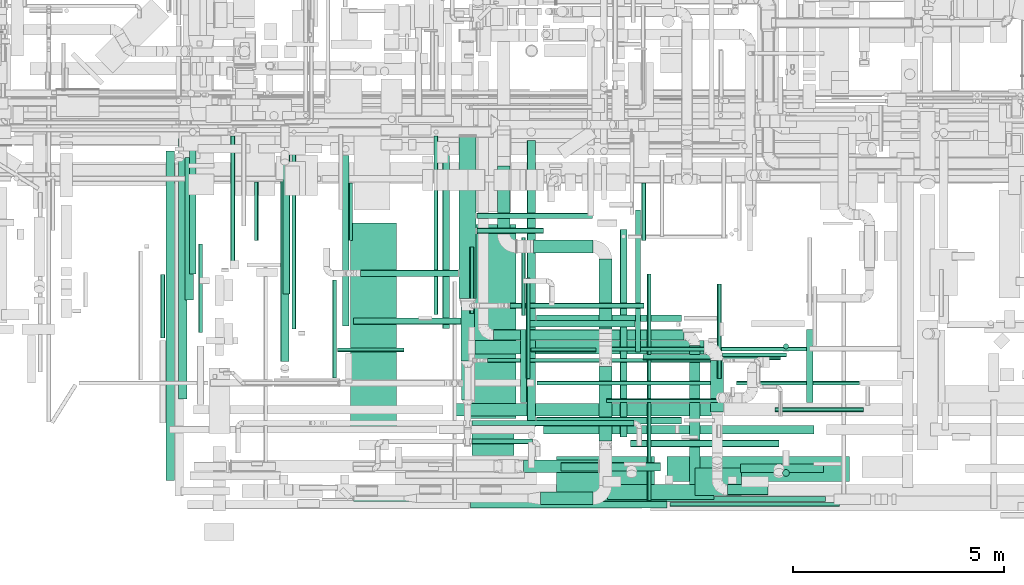
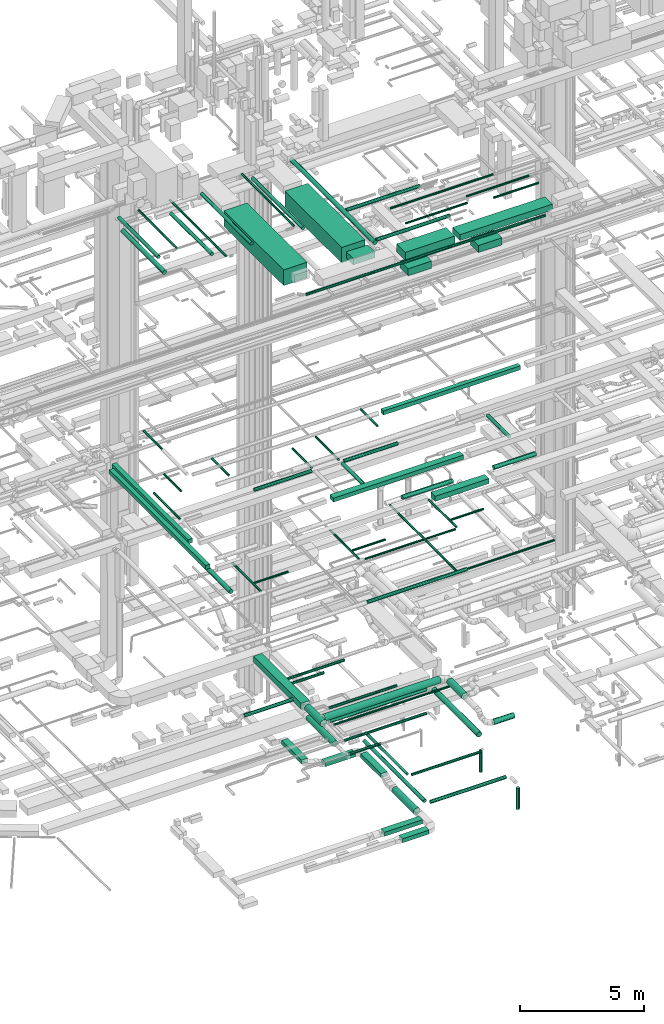
# One storey, part 30 of 337: 79 flow segments.
"""IFC2X3 building model written with IfcOpenShell, lengths in millimetres."""

from ifc_helpers import new_model, entity, si_unit, converted_unit, derived_unit, direction, frame, origin, origin_2d_with_axis, place, context, subcontext, project, spatial, rectangle, circle, extrude, type_object, element, save


model = new_model("IFC2X3")

# Units and contexts
model_context = context("Model", 3, precision=0.01, world=origin(), true_north=direction((6.12303176911189e-17, 1.0)))
body_context = subcontext(model_context, "Body", "Model", "MODEL_VIEW")
ifc_project = project(units=[si_unit("LENGTHUNIT", "METRE", prefix="MILLI"), si_unit("AREAUNIT", "SQUARE_METRE"), si_unit("VOLUMEUNIT", "CUBIC_METRE"), converted_unit("PLANEANGLEUNIT", "DEGREE", entity("IfcRatioMeasure", 0.0174532925199433), si_unit("PLANEANGLEUNIT", "RADIAN"), dimensions=[0, 0, 0, 0, 0, 0, 0]), si_unit("MASSUNIT", "GRAM", prefix="KILO"), derived_unit("MASSDENSITYUNIT", [(si_unit("MASSUNIT", "GRAM", prefix="KILO"), 1), (si_unit("LENGTHUNIT", "METRE"), -3)]), derived_unit("MOMENTOFINERTIAUNIT", [(si_unit("LENGTHUNIT", "METRE"), 4)]), si_unit("TIMEUNIT", "SECOND"), si_unit("FREQUENCYUNIT", "HERTZ"), si_unit("THERMODYNAMICTEMPERATUREUNIT", "DEGREE_CELSIUS"), derived_unit("THERMALTRANSMITTANCEUNIT", [(si_unit("MASSUNIT", "GRAM", prefix="KILO"), 1), (si_unit("THERMODYNAMICTEMPERATUREUNIT", "KELVIN"), -1), (si_unit("TIMEUNIT", "SECOND"), -3)]), derived_unit("VOLUMETRICFLOWRATEUNIT", [(si_unit("LENGTHUNIT", "METRE"), 3), (si_unit("TIMEUNIT", "SECOND"), -1)]), derived_unit("MASSFLOWRATEUNIT", [(si_unit("MASSUNIT", "GRAM", prefix="KILO"), 1), (si_unit("TIMEUNIT", "SECOND"), -1)]), derived_unit("ROTATIONALFREQUENCYUNIT", [(si_unit("TIMEUNIT", "SECOND"), -1)]), si_unit("ELECTRICCURRENTUNIT", "AMPERE"), si_unit("ELECTRICVOLTAGEUNIT", "VOLT"), si_unit("POWERUNIT", "WATT"), si_unit("FORCEUNIT", "NEWTON", prefix="KILO"), si_unit("ILLUMINANCEUNIT", "LUX"), si_unit("LUMINOUSFLUXUNIT", "LUMEN"), si_unit("LUMINOUSINTENSITYUNIT", "CANDELA"), derived_unit("USERDEFINED", [(si_unit("MASSUNIT", "GRAM", prefix="KILO"), -1), (si_unit("LENGTHUNIT", "METRE"), -2), (si_unit("TIMEUNIT", "SECOND"), 3), (si_unit("LUMINOUSFLUXUNIT", "LUMEN"), 1)]), derived_unit("LINEARVELOCITYUNIT", [(si_unit("LENGTHUNIT", "METRE"), 1), (si_unit("TIMEUNIT", "SECOND"), -1)]), si_unit("PRESSUREUNIT", "PASCAL"), derived_unit("USERDEFINED", [(si_unit("LENGTHUNIT", "METRE"), -2), (si_unit("MASSUNIT", "GRAM", prefix="KILO"), 1), (si_unit("TIMEUNIT", "SECOND"), -2)]), derived_unit("LINEARFORCEUNIT", [(si_unit("MASSUNIT", "GRAM", prefix="KILO"), 1), (si_unit("LENGTHUNIT", "METRE"), 1), (si_unit("TIMEUNIT", "SECOND"), -2), (si_unit("LENGTHUNIT", "METRE"), -1)]), derived_unit("PLANARFORCEUNIT", [(si_unit("MASSUNIT", "GRAM", prefix="KILO"), 1), (si_unit("LENGTHUNIT", "METRE"), 1), (si_unit("TIMEUNIT", "SECOND"), -2), (si_unit("LENGTHUNIT", "METRE"), -2)])], contexts=[model_context])

# Site, building, storey
site_placement = place(None, origin())
site = spatial("IfcSite", under=ifc_project, at=site_placement, CompositionType="ELEMENT")
building_placement = place(site_placement, origin())
building = spatial("IfcBuilding", under=site, at=building_placement, CompositionType="ELEMENT")
storey_placement = place(building_placement, origin())
storey = spatial("IfcBuildingStorey", under=building, at=storey_placement, CompositionType="ELEMENT", Elevation=0.0)

# Flow segments
duct_segment_type_1 = type_object("IfcDuctSegmentType", PredefinedType="NOTDEFINED")
flow_segment_1_placement = place(storey_placement, frame((30327.78, 6910.62, -650.0)))
element("IfcFlowSegment", 1, at=flow_segment_1_placement, inside=storey, type_object=duct_segment_type_1, context=body_context, shape_type="SweptSolid", body=[
    extrude(rectangle(XDim=1613.81498356853, YDim=300.000000000001, at=origin_2d_with_axis()), frame((150.0, 806.91, 0.0), z_axis=(0.0, 0.0, 1.0), x_axis=(0.0, 1.0, 0.0)), (0.0, 0.0, 1.0), 200.0),
])
flow_segment_2_placement = place(storey_placement, frame((32739.74, 4657.73, -800.0)))
element("IfcFlowSegment", 2, at=flow_segment_2_placement, inside=storey, type_object=duct_segment_type_1, context=body_context, shape_type="SweptSolid", body=[
    extrude(rectangle(XDim=1652.88388777232, YDim=300.000000000001, at=origin_2d_with_axis()), frame((150.0, 826.44, 0.0), z_axis=(0.0, 0.0, 1.0), x_axis=(0.0, -1.0, 0.0)), (0.0, 0.0, 1.0), 200.0),
])
flow_segment_3_placement = place(storey_placement, frame((31351.06, 498.22, -1000.0)))
element("IfcFlowSegment", 3, at=flow_segment_3_placement, inside=storey, type_object=duct_segment_type_1, context=body_context, shape_type="SweptSolid", body=[
    extrude(rectangle(XDim=1238.6873062339, YDim=300.0, at=origin_2d_with_axis()), frame((619.34, 150.0, 0.0), z_axis=(0.0, 0.0, 1.0), x_axis=(-1.0, 0.0, 0.0)), (0.0, 0.0, 1.0), 200.0),
])
flow_segment_4_placement = place(storey_placement, frame((30943.84, 1257.6, -1000.0)))
element("IfcFlowSegment", 4, at=flow_segment_4_placement, inside=storey, type_object=duct_segment_type_1, context=body_context, shape_type="SweptSolid", body=[
    extrude(rectangle(XDim=1775.90363974999, YDim=300.0, at=origin_2d_with_axis()), frame((887.95, 150.0, 0.0), z_axis=(0.0, 0.0, 1.0), x_axis=(-1.0, 0.0, 0.0)), (0.0, 0.0, 1.0), 200.0),
])
flow_segment_5_placement = place(storey_placement, frame((29425.76, 5379.25, 3300.0)))
element("IfcFlowSegment", 5, at=flow_segment_5_placement, inside=storey, type_object=duct_segment_type_1, context=body_context, shape_type="SweptSolid", body=[
    extrude(rectangle(XDim=3849.82756057298, YDim=400.0, at=origin_2d_with_axis()), frame((200.0, 1924.91, 0.0), z_axis=(0.0, 0.0, 1.0), x_axis=(0.0, 1.0, 0.0)), (0.0, 0.0, 1.0), 300.0),
])
flow_segment_6_placement = place(storey_placement, frame((31425.22, 2176.32, 19075.0)))
element("IfcFlowSegment", 6, at=flow_segment_6_placement, inside=storey, type_object=duct_segment_type_1, context=body_context, shape_type="SweptSolid", body=[
    extrude(rectangle(XDim=6399.99999999994, YDim=200.0, at=origin_2d_with_axis()), frame((3200.0, 100.0, 0.0), z_axis=(0.0, 0.0, 1.0), x_axis=(-1.0, 0.0, 0.0)), (0.0, 0.0, 1.0), 199.999999999998),
])
flow_segment_7_placement = place(storey_placement, frame((29338.8, 2599.02, 15250.0)))
element("IfcFlowSegment", 7, at=flow_segment_7_placement, inside=storey, type_object=duct_segment_type_1, context=body_context, shape_type="SweptSolid", body=[
    extrude(rectangle(XDim=6062.99999999993, YDim=300.0, at=origin_2d_with_axis()), frame((3031.5, 150.0, 0.0)), (0.0, 0.0, 1.0), 199.999999999998),
])
flow_segment_8_placement = place(storey_placement, frame((32940.93, 620.66, 15225.0)))
element("IfcFlowSegment", 8, at=flow_segment_8_placement, inside=storey, type_object=duct_segment_type_1, context=body_context, shape_type="SweptSolid", body=[
    extrude(rectangle(XDim=2514.00000000004, YDim=350.0, at=origin_2d_with_axis()), frame((1257.0, 175.0, 0.0)), (0.0, 0.0, 1.0), 249.999999999999),
])
flow_segment_9_placement = place(storey_placement, frame((22482.56, 1070.66, 15250.0)))
element("IfcFlowSegment", 9, at=flow_segment_9_placement, inside=storey, type_object=duct_segment_type_1, context=body_context, shape_type="SweptSolid", body=[
    extrude(rectangle(XDim=7807.60125080103, YDim=199.999999999998, at=origin_2d_with_axis()), frame((100.0, 3903.8, 0.0), z_axis=(0.0, 0.0, 1.0), x_axis=(0.0, -1.0, 0.0)), (0.0, 0.0, 1.0), 200.000000000002),
])
flow_segment_10_placement = place(storey_placement, frame((22777.55, 2999.02, 15250.0)))
element("IfcFlowSegment", 10, at=flow_segment_10_placement, inside=storey, type_object=duct_segment_type_1, context=body_context, shape_type="SweptSolid", body=[
    extrude(rectangle(XDim=6170.97709351263, YDim=200.000000000002, at=origin_2d_with_axis()), frame((100.0, 3085.49, 0.0), z_axis=(0.0, 0.0, 1.0), x_axis=(0.0, 1.0, 0.0)), (0.0, 0.0, 1.0), 200.000000000002),
])
flow_segment_11_placement = place(storey_placement, frame((26855.62, 2334.06, 26975.0)))
element("IfcFlowSegment", 11, at=flow_segment_11_placement, inside=storey, type_object=duct_segment_type_1, context=body_context, shape_type="SweptSolid", body=[
    extrude(rectangle(XDim=4840.00000000023, YDim=1090.0, at=origin_2d_with_axis()), frame((545.0, 2420.0, 0.0), z_axis=(0.0, 0.0, 1.0), x_axis=(0.0, -1.0, 0.0)), (0.0, 0.0, 1.0), 769.999999999998),
])
flow_segment_12_placement = place(storey_placement, frame((34353.0, 1044.06, 27350.0)))
element("IfcFlowSegment", 12, at=flow_segment_12_placement, inside=storey, type_object=duct_segment_type_1, context=body_context, shape_type="SweptSolid", body=[
    extrude(rectangle(XDim=4317.00000000009, YDim=600.0, at=origin_2d_with_axis()), frame((2158.5, 300.0, 0.0), z_axis=(0.0, 0.0, 1.0), x_axis=(-1.0, 0.0, 0.0)), (0.0, 0.0, 1.0), 300.000000000001),
])
flow_segment_13_placement = place(storey_placement, frame((29679.65, 2532.81, 26980.0)))
element("IfcFlowSegment", 13, at=flow_segment_13_placement, inside=storey, type_object=duct_segment_type_1, context=body_context, shape_type="SweptSolid", body=[
    extrude(rectangle(XDim=4600.00000000022, YDim=1090.0, at=origin_2d_with_axis()), frame((545.0, 2300.0, 0.0), z_axis=(0.0, 0.0, 1.0), x_axis=(0.0, -1.0, 0.0)), (0.0, 0.0, 1.0), 769.999999999998),
])
flow_segment_14_placement = place(storey_placement, frame((29724.65, 1664.06, 27400.0)))
element("IfcFlowSegment", 14, at=flow_segment_14_placement, inside=storey, type_object=duct_segment_type_1, context=body_context, shape_type="SweptSolid", body=[
    extrude(rectangle(XDim=568.74999999973, YDim=1000.0, at=origin_2d_with_axis()), frame((500.0, 284.37, 0.0), z_axis=(0.0, 0.0, 1.0), x_axis=(0.0, 1.0, 0.0)), (0.0, 0.0, 1.0), 300.000000000001),
])
flow_segment_15_placement = place(storey_placement, frame((31733.0, 944.06, 27350.0)))
element("IfcFlowSegment", 15, at=flow_segment_15_placement, inside=storey, type_object=duct_segment_type_1, context=body_context, shape_type="SweptSolid", body=[
    extrude(rectangle(XDim=2320.00000000006, YDim=700.0, at=origin_2d_with_axis()), frame((1160.0, 350.0, 0.0)), (0.0, 0.0, 1.0), 399.999999999996),
])
for number, where in (
    (16, (35014.8, 718.17, 26725.0)),
    (17, (31734.8, 718.17, 26725.0)),
):
    element("IfcFlowSegment", number, at=place(storey_placement, frame(where)), inside=storey, type_object=duct_segment_type_1, context=body_context, shape_type="SweptSolid", body=[
        extrude(rectangle(XDim=1100.0, YDim=650.0, at=origin_2d_with_axis()), frame((550.0, 325.0, 0.0)), (0.0, 0.0, 1.0), 349.999999999998),
    ])
flow_segment_16_placement = place(storey_placement, frame((31183.96, 6460.62, -800.0)))
element("IfcFlowSegment", 18, at=flow_segment_16_placement, inside=storey, type_object=duct_segment_type_1, context=body_context, shape_type="SweptSolid", body=[
    extrude(rectangle(XDim=1405.78843504311, YDim=300.0, at=origin_2d_with_axis()), frame((702.89, 150.0, 0.0), z_axis=(0.0, 0.0, 1.0), x_axis=(-1.0, 0.0, 0.0)), (0.0, 0.0, 1.0), 200.0),
])
duct_segment_type_2 = type_object("IfcDuctSegmentType", PredefinedType="NOTDEFINED")
flow_segment_17_placement = place(storey_placement, frame((32730.65, 2009.57, -1059.1)))
element("IfcFlowSegment", 19, at=flow_segment_17_placement, inside=storey, type_object=duct_segment_type_2, context=body_context, shape_type="SweptSolid", body=[
    extrude(circle(Radius=157.5, at=origin_2d_with_axis()), frame((159.1, 0.0, 159.1), z_axis=(0.0, 1.0, 0.0), x_axis=(-1.0, 0.0, 0.0)), (0.0, 0.0, 1.0), 1762.90332573453),
])
flow_segment_18_placement = place(storey_placement, frame((33594.55, 4113.76, -664.1)))
element("IfcFlowSegment", 20, at=flow_segment_18_placement, inside=storey, type_object=duct_segment_type_2, context=body_context, shape_type="SweptSolid", body=[
    extrude(circle(Radius=62.5, at=origin_2d_with_axis()), frame((64.1, 0.0, 64.1), z_axis=(0.0, 1.0, 0.0), x_axis=(-1.0, 0.0, 0.0)), (0.0, 0.0, 1.0), 3361.01449),
])
flow_segment_19_placement = place(storey_placement, frame((33783.65, 3924.66, -664.1)))
element("IfcFlowSegment", 21, at=flow_segment_19_placement, inside=storey, type_object=duct_segment_type_2, context=body_context, shape_type="SweptSolid", body=[
    extrude(circle(Radius=62.5, at=origin_2d_with_axis()), frame((0.0, 64.1, 64.1), z_axis=(1.0, 0.0, 0.0), x_axis=(0.0, -1.0, 0.0)), (0.0, 0.0, 1.0), 3255.64254),
])
flow_segment_20_placement = place(storey_placement, frame((37100.2, 4184.59, -1800.0)))
element("IfcFlowSegment", 22, at=flow_segment_20_placement, inside=storey, type_object=duct_segment_type_2, context=body_context, shape_type="SweptSolid", body=[
    extrude(circle(Radius=62.5, at=origin_2d_with_axis()), frame((64.1, 64.1, 0.0), z_axis=(0.0, 0.0, 1.0), x_axis=(-1.0, 0.0, 0.0)), (0.0, 0.0, 1.0), 1075.0),
])
flow_segment_21_placement = place(storey_placement, frame((33236.76, 2104.27, -681.6)))
element("IfcFlowSegment", 23, at=flow_segment_21_placement, inside=storey, type_object=duct_segment_type_2, context=body_context, shape_type="SweptSolid", body=[
    extrude(circle(Radius=80.0, at=origin_2d_with_axis()), frame((81.6, 0.0, 81.6), z_axis=(0.0, 1.0, 0.0), x_axis=(-1.0, 0.0, 0.0)), (0.0, 0.0, 1.0), 4905.24999),
])
flow_segment_22_placement = place(storey_placement, frame((33478.35, 1862.68, -681.6)))
element("IfcFlowSegment", 24, at=flow_segment_22_placement, inside=storey, type_object=duct_segment_type_2, context=body_context, shape_type="SweptSolid", body=[
    extrude(circle(Radius=80.0, at=origin_2d_with_axis()), frame((0.0, 81.6, 81.6), z_axis=(1.0, 0.0, 0.0), x_axis=(0.0, -1.0, 0.0)), (0.0, 0.0, 1.0), 3525.91623000001),
])
flow_segment_23_placement = place(storey_placement, frame((37082.67, 1167.05, -1800.0)))
element("IfcFlowSegment", 25, at=flow_segment_23_placement, inside=storey, type_object=duct_segment_type_2, context=body_context, shape_type="SweptSolid", body=[
    extrude(circle(Radius=80.0, at=origin_2d_with_axis()), frame((81.6, 81.6, 0.0), z_axis=(0.0, 0.0, 1.0), x_axis=(-1.0, 0.0, 0.0)), (0.0, 0.0, 1.0), 1040.0),
])
flow_segment_24_placement = place(storey_placement, frame((29692.77, 418.42, 11388.4)))
element("IfcFlowSegment", 26, at=flow_segment_24_placement, inside=storey, type_object=duct_segment_type_2, context=body_context, shape_type="SweptSolid", body=[
    extrude(circle(Radius=80.0, at=origin_2d_with_axis()), frame((0.0, 81.6, 81.6), z_axis=(1.0, 0.0, 0.0), x_axis=(0.0, -1.0, 0.0)), (0.0, 0.0, 1.0), 4659.99999999999),
])
flow_segment_25_placement = place(storey_placement, frame((34412.77, 448.42, 11418.4)))
element("IfcFlowSegment", 27, at=flow_segment_25_placement, inside=storey, type_object=duct_segment_type_2, context=body_context, shape_type="SweptSolid", body=[
    extrude(circle(Radius=50.0, at=origin_2d_with_axis()), frame((0.0, 51.6, 51.6), z_axis=(1.0, 0.0, 0.0), x_axis=(0.0, -1.0, 0.0)), (0.0, 0.0, 1.0), 4019.99999999999),
])
flow_segment_26_placement = place(storey_placement, frame((25195.7, 3884.1, 11368.4)))
element("IfcFlowSegment", 28, at=flow_segment_26_placement, inside=storey, type_object=duct_segment_type_2, context=body_context, shape_type="SweptSolid", body=[
    extrude(circle(Radius=100.0, at=origin_2d_with_axis()), frame((101.6, 0.0, 101.6), z_axis=(0.0, 1.0, 0.0), x_axis=(-1.0, 0.0, 0.0)), (0.0, 0.0, 1.0), 4587.1204989029),
])
flow_segment_27_placement = place(storey_placement, frame((26417.63, 3500.54, 11248.4)))
element("IfcFlowSegment", 29, at=flow_segment_27_placement, inside=storey, type_object=duct_segment_type_2, context=body_context, shape_type="SweptSolid", body=[
    extrude(circle(Radius=50.0, at=origin_2d_with_axis()), frame((51.6, 0.0, 51.6), z_axis=(0.0, 1.0, 0.0), x_axis=(1.0, 0.0, 0.0)), (0.0, 0.0, 1.0), 2320.0),
])
flow_segment_28_placement = place(storey_placement, frame((26539.23, 4108.95, 11248.4)))
element("IfcFlowSegment", 30, at=flow_segment_28_placement, inside=storey, type_object=duct_segment_type_2, context=body_context, shape_type="SweptSolid", body=[
    extrude(circle(Radius=50.0, at=origin_2d_with_axis()), frame((0.0, 51.6, 51.6), z_axis=(1.0, 0.0, 0.0), x_axis=(0.0, -1.0, 0.0)), (0.0, 0.0, 1.0), 1579.99999999999),
])
flow_segment_29_placement = place(storey_placement, frame((31262.3, 3328.95, 11248.4)))
element("IfcFlowSegment", 31, at=flow_segment_29_placement, inside=storey, type_object=duct_segment_type_2, context=body_context, shape_type="SweptSolid", body=[
    extrude(circle(Radius=50.0, at=origin_2d_with_axis()), frame((0.0, 51.6, 51.6), z_axis=(1.0, 0.0, 0.0), x_axis=(0.0, -1.0, 0.0)), (0.0, 0.0, 1.0), 4225.0),
])
flow_segment_30_placement = place(storey_placement, frame((35535.7, 3480.54, 11248.4)))
element("IfcFlowSegment", 32, at=flow_segment_30_placement, inside=storey, type_object=duct_segment_type_2, context=body_context, shape_type="SweptSolid", body=[
    extrude(circle(Radius=50.0, at=origin_2d_with_axis()), frame((51.6, 0.0, 51.6), z_axis=(0.0, 1.0, 0.0), x_axis=(1.0, 0.0, 0.0)), (0.0, 0.0, 1.0), 2240.0),
])
flow_segment_31_placement = place(storey_placement, frame((31002.42, 3480.54, 11248.4)))
element("IfcFlowSegment", 33, at=flow_segment_31_placement, inside=storey, type_object=duct_segment_type_2, context=body_context, shape_type="SweptSolid", body=[
    extrude(circle(Radius=50.0, at=origin_2d_with_axis()), frame((51.6, 0.0, 51.6), z_axis=(0.0, 1.0, 0.0), x_axis=(1.0, 0.0, 0.0)), (0.0, 0.0, 1.0), 2380.00000000042),
])
flow_segment_32_placement = place(storey_placement, frame((31124.01, 4108.95, 11248.4)))
element("IfcFlowSegment", 34, at=flow_segment_32_placement, inside=storey, type_object=duct_segment_type_2, context=body_context, shape_type="SweptSolid", body=[
    extrude(circle(Radius=50.0, at=origin_2d_with_axis()), frame((0.0, 51.6, 51.6), z_axis=(1.0, 0.0, 0.0), x_axis=(0.0, -1.0, 0.0)), (0.0, 0.0, 1.0), 1539.99999999996),
])
flow_segment_33_placement = place(storey_placement, frame((35657.3, 3988.95, 11248.4)))
element("IfcFlowSegment", 35, at=flow_segment_33_placement, inside=storey, type_object=duct_segment_type_2, context=body_context, shape_type="SweptSolid", body=[
    extrude(circle(Radius=50.0, at=origin_2d_with_axis()), frame((0.0, 51.6, 51.6), z_axis=(1.0, 0.0, 0.0), x_axis=(0.0, -1.0, 0.0)), (0.0, 0.0, 1.0), 1519.99999999998),
])
flow_segment_34_placement = place(storey_placement, frame((33868.9, 600.02, 11418.4)))
element("IfcFlowSegment", 36, at=flow_segment_34_placement, inside=storey, type_object=duct_segment_type_2, context=body_context, shape_type="SweptSolid", body=[
    extrude(circle(Radius=50.0, at=origin_2d_with_axis()), frame((51.6, 0.0, 51.6), z_axis=(0.0, 1.0, 0.0), x_axis=(1.0, 0.0, 0.0)), (0.0, 0.0, 1.0), 5357.86105600282),
])
flow_segment_35_placement = place(storey_placement, frame((29845.76, 7277.17, 3385.9)))
element("IfcFlowSegment", 37, at=flow_segment_35_placement, inside=storey, type_object=duct_segment_type_2, context=body_context, shape_type="SweptSolid", body=[
    extrude(circle(Radius=62.5, at=origin_2d_with_axis()), frame((0.0, 64.1, 64.1), z_axis=(1.0, 0.0, 0.0), x_axis=(0.0, -1.0, 0.0)), (0.0, 0.0, 1.0), 2739.99999999998),
])
flow_segment_36_placement = place(storey_placement, frame((29845.76, 6918.33, 3385.9)))
element("IfcFlowSegment", 38, at=flow_segment_36_placement, inside=storey, type_object=duct_segment_type_2, context=body_context, shape_type="SweptSolid", body=[
    extrude(circle(Radius=62.5, at=origin_2d_with_axis()), frame((0.0, 64.1, 64.1), z_axis=(1.0, 0.0, 0.0), x_axis=(0.0, -1.0, 0.0)), (0.0, 0.0, 1.0), 1574.99999999999),
])
flow_segment_37_placement = place(storey_placement, frame((27082.03, 5894.29, 3368.4)))
element("IfcFlowSegment", 39, at=flow_segment_37_placement, inside=storey, type_object=duct_segment_type_2, context=body_context, shape_type="SweptSolid", body=[
    extrude(circle(Radius=80.0, at=origin_2d_with_axis()), frame((0.0, 81.6, 81.6), z_axis=(1.0, 0.0, 0.0), x_axis=(0.0, 1.0, 0.0)), (0.0, 0.0, 1.0), 2323.72583002021),
])
flow_segment_38_placement = place(storey_placement, frame((29466.66, 3899.25, 3290.9)))
element("IfcFlowSegment", 40, at=flow_segment_38_placement, inside=storey, type_object=duct_segment_type_2, context=body_context, shape_type="SweptSolid", body=[
    extrude(circle(Radius=157.5, at=origin_2d_with_axis()), frame((159.1, 0.0, 159.1), z_axis=(0.0, 1.0, 0.0), x_axis=(-1.0, 0.0, 0.0)), (0.0, 0.0, 1.0), 1280.0),
])
flow_segment_39_placement = place(storey_placement, frame((29725.76, 2360.54, 3385.9)))
element("IfcFlowSegment", 41, at=flow_segment_39_placement, inside=storey, type_object=duct_segment_type_2, context=body_context, shape_type="SweptSolid", body=[
    extrude(circle(Radius=62.5, at=origin_2d_with_axis()), frame((0.0, 64.1, 64.1), z_axis=(1.0, 0.0, 0.0), x_axis=(0.0, 1.0, 0.0)), (0.0, 0.0, 1.0), 3837.44887343672),
])
flow_segment_40_placement = place(storey_placement, frame((29803.26, 4067.69, 3290.9)))
element("IfcFlowSegment", 42, at=flow_segment_40_placement, inside=storey, type_object=duct_segment_type_2, context=body_context, shape_type="SweptSolid", body=[
    extrude(circle(Radius=157.5, at=origin_2d_with_axis()), frame((0.0, 159.1, 159.1), z_axis=(1.0, 0.0, 0.0), x_axis=(0.0, 1.0, 0.0)), (0.0, 0.0, 1.0), 5415.0),
])
flow_segment_41_placement = place(storey_placement, frame((35374.16, 2691.79, 3290.9)))
element("IfcFlowSegment", 43, at=flow_segment_41_placement, inside=storey, type_object=duct_segment_type_2, context=body_context, shape_type="SweptSolid", body=[
    extrude(circle(Radius=157.5, at=origin_2d_with_axis()), frame((159.1, 0.0, 159.1), z_axis=(0.0, 1.0, 0.0), x_axis=(-1.0, 0.0, 0.0)), (0.0, 0.0, 1.0), 1220.00000000001),
])
flow_segment_42_placement = place(storey_placement, frame((35783.26, 725.19, 3073.4)))
element("IfcFlowSegment", 44, at=flow_segment_42_placement, inside=storey, type_object=duct_segment_type_2, context=body_context, shape_type="SweptSolid", body=[
    extrude(circle(Radius=125.0, at=origin_2d_with_axis()), frame((0.0, 126.6, 126.6), z_axis=(1.0, 0.0, 0.0), x_axis=(0.0, -1.0, 0.0)), (0.0, 0.0, 1.0), 960.000000000003),
])
flow_segment_43_placement = place(storey_placement, frame((29482.65, 2976.01, 2858.4)))
element("IfcFlowSegment", 45, at=flow_segment_43_placement, inside=storey, type_object=duct_segment_type_2, context=body_context, shape_type="SweptSolid", body=[
    extrude(circle(Radius=140.0, at=origin_2d_with_axis()), frame((141.6, 0.0, 141.6), z_axis=(0.0, 1.0, 0.0), x_axis=(1.0, 0.0, 0.0)), (0.0, 0.0, 1.0), 2123.33716282241),
])
flow_segment_44_placement = place(storey_placement, frame((29723.26, 1931.61, 2985.9)))
element("IfcFlowSegment", 46, at=flow_segment_44_placement, inside=storey, type_object=duct_segment_type_2, context=body_context, shape_type="SweptSolid", body=[
    extrude(circle(Radius=62.5, at=origin_2d_with_axis()), frame((0.0, 64.1, 64.1), z_axis=(1.0, 0.0, 0.0), x_axis=(0.0, 1.0, 0.0)), (0.0, 0.0, 1.0), 1440.76353646643),
])
flow_segment_45_placement = place(storey_placement, frame((30097.36, 3857.96, 3148.4)))
element("IfcFlowSegment", 47, at=flow_segment_45_placement, inside=storey, type_object=duct_segment_type_2, context=body_context, shape_type="SweptSolid", body=[
    extrude(circle(Radius=50.0, at=origin_2d_with_axis()), frame((0.0, 51.6, 51.6), z_axis=(1.0, 0.0, 0.0), x_axis=(0.0, 1.0, 0.0)), (0.0, 0.0, 1.0), 5567.03573647825),
])
flow_segment_46_placement = place(storey_placement, frame((30628.58, 5147.75, 2985.9)))
element("IfcFlowSegment", 48, at=flow_segment_46_placement, inside=storey, type_object=duct_segment_type_2, context=body_context, shape_type="SweptSolid", body=[
    extrude(circle(Radius=62.5, at=origin_2d_with_axis()), frame((0.0, 64.1, 64.1), z_axis=(1.0, 0.0, 0.0), x_axis=(0.0, -1.0, 0.0)), (0.0, 0.0, 1.0), 3168.22330470337),
])
flow_segment_47_placement = place(storey_placement, frame((30241.01, 4393.88, 2873.4)))
element("IfcFlowSegment", 49, at=flow_segment_47_placement, inside=storey, type_object=duct_segment_type_2, context=body_context, shape_type="SweptSolid", body=[
    extrude(circle(Radius=125.0, at=origin_2d_with_axis()), frame((0.0, 126.6, 126.6), z_axis=(1.0, 0.0, 0.0), x_axis=(0.0, 1.0, 0.0)), (0.0, 0.0, 1.0), 4510.0),
])
flow_segment_48_placement = place(storey_placement, frame((34874.42, 620.16, 2873.4)))
element("IfcFlowSegment", 50, at=flow_segment_48_placement, inside=storey, type_object=duct_segment_type_2, context=body_context, shape_type="SweptSolid", body=[
    extrude(circle(Radius=125.0, at=origin_2d_with_axis()), frame((126.6, 0.0, 126.6), z_axis=(0.0, 1.0, 0.0), x_axis=(-1.0, 0.0, 0.0)), (0.0, 0.0, 1.0), 3650.31250000001),
])
flow_segment_49_placement = place(storey_placement, frame((23244.23, 4570.44, 15298.4)))
element("IfcFlowSegment", 51, at=flow_segment_49_placement, inside=storey, type_object=duct_segment_type_2, context=body_context, shape_type="SweptSolid", body=[
    extrude(circle(Radius=50.0, at=origin_2d_with_axis()), frame((51.6, 0.0, 51.6), z_axis=(0.0, 1.0, 0.0), x_axis=(1.0, 0.0, 0.0)), (0.0, 0.0, 1.0), 2097.897162323),
])
flow_segment_50_placement = place(storey_placement, frame((29672.93, 5030.44, 15298.4)))
element("IfcFlowSegment", 52, at=flow_segment_50_placement, inside=storey, type_object=duct_segment_type_2, context=body_context, shape_type="SweptSolid", body=[
    extrude(circle(Radius=50.0, at=origin_2d_with_axis()), frame((51.6, 0.0, 51.6), z_axis=(0.0, 1.0, 0.0), x_axis=(-1.0, 0.0, 0.0)), (0.0, 0.0, 1.0), 1565.99999999964),
])
flow_segment_51_placement = place(storey_placement, frame((30869.88, 2919.02, 15268.4)))
element("IfcFlowSegment", 53, at=flow_segment_51_placement, inside=storey, type_object=duct_segment_type_2, context=body_context, shape_type="SweptSolid", body=[
    extrude(circle(Radius=80.0, at=origin_2d_with_axis()), frame((81.6, 0.0, 81.6), z_axis=(0.0, 1.0, 0.0), x_axis=(1.0, 0.0, 0.0)), (0.0, 0.0, 1.0), 1733.06945623725),
])
flow_segment_52_placement = place(storey_placement, frame((30899.88, 4972.09, 15298.4)))
element("IfcFlowSegment", 54, at=flow_segment_52_placement, inside=storey, type_object=duct_segment_type_2, context=body_context, shape_type="SweptSolid", body=[
    extrude(circle(Radius=50.0, at=origin_2d_with_axis()), frame((51.6, 0.0, 51.6), z_axis=(0.0, 1.0, 0.0), x_axis=(1.0, 0.0, 0.0)), (0.0, 0.0, 1.0), 1858.3519000001),
])
flow_segment_53_placement = place(storey_placement, frame((22350.34, 4448.82, 19123.4)))
element("IfcFlowSegment", 55, at=flow_segment_53_placement, inside=storey, type_object=duct_segment_type_2, context=body_context, shape_type="SweptSolid", body=[
    extrude(circle(Radius=50.0, at=origin_2d_with_axis()), frame((51.6, 0.0, 51.6), z_axis=(0.0, 1.0, 0.0), x_axis=(1.0, 0.0, 0.0)), (0.0, 0.0, 1.0), 1499.99999999999),
])
flow_segment_54_placement = place(storey_placement, frame((31835.07, 1289.06, 15248.4)))
element("IfcFlowSegment", 56, at=flow_segment_54_placement, inside=storey, type_object=duct_segment_type_2, context=body_context, shape_type="SweptSolid", body=[
    extrude(circle(Radius=100.0, at=origin_2d_with_axis()), frame((0.0, 101.6, 101.6), z_axis=(1.0, 0.0, 0.0), x_axis=(0.0, 1.0, 0.0)), (0.0, 0.0, 1.0), 2360.00000000001),
])
flow_segment_55_placement = place(storey_placement, frame((36089.75, 1260.8, 15248.4)))
element("IfcFlowSegment", 57, at=flow_segment_55_placement, inside=storey, type_object=duct_segment_type_2, context=body_context, shape_type="SweptSolid", body=[
    extrude(circle(Radius=100.0, at=origin_2d_with_axis()), frame((0.0, 101.6, 101.6), z_axis=(1.0, 0.0, 0.0), x_axis=(0.0, -1.0, 0.0)), (0.0, 0.0, 1.0), 1960.0),
])
flow_segment_56_placement = place(storey_placement, frame((26924.52, 4758.85, 15268.4)))
element("IfcFlowSegment", 58, at=flow_segment_56_placement, inside=storey, type_object=duct_segment_type_2, context=body_context, shape_type="SweptSolid", body=[
    extrude(circle(Radius=80.0, at=origin_2d_with_axis()), frame((0.0, 81.6, 81.6), z_axis=(1.0, 0.0, 0.0), x_axis=(0.0, 1.0, 0.0)), (0.0, 0.0, 1.0), 2669.99999991096),
])
flow_segment_57_placement = place(storey_placement, frame((31081.47, 4700.5, 15268.4)))
element("IfcFlowSegment", 59, at=flow_segment_57_placement, inside=storey, type_object=duct_segment_type_2, context=body_context, shape_type="SweptSolid", body=[
    extrude(circle(Radius=80.0, at=origin_2d_with_axis()), frame((0.0, 81.6, 81.6), z_axis=(1.0, 0.0, 0.0), x_axis=(0.0, -1.0, 0.0)), (0.0, 0.0, 1.0), 2509.99999994373),
])
flow_segment_58_placement = place(storey_placement, frame((37647.16, 2919.02, 15268.4)))
element("IfcFlowSegment", 60, at=flow_segment_58_placement, inside=storey, type_object=duct_segment_type_2, context=body_context, shape_type="SweptSolid", body=[
    extrude(circle(Radius=80.0, at=origin_2d_with_axis()), frame((81.6, 0.0, 81.6), z_axis=(0.0, 1.0, 0.0), x_axis=(-1.0, 0.0, 0.0)), (0.0, 0.0, 1.0), 1733.06945623728),
])
flow_segment_59_placement = place(storey_placement, frame((33743.63, 6759.63, 14873.4)))
element("IfcFlowSegment", 61, at=flow_segment_59_placement, inside=storey, type_object=duct_segment_type_2, context=body_context, shape_type="SweptSolid", body=[
    extrude(circle(Radius=50.0, at=origin_2d_with_axis()), frame((51.6, 0.0, 51.6), z_axis=(0.0, 1.0, 0.0), x_axis=(-1.0, 0.0, 0.0)), (0.0, 0.0, 1.0), 1360.00000000023),
])
flow_segment_60_placement = place(storey_placement, frame((26798.36, 6759.63, 14873.4)))
element("IfcFlowSegment", 62, at=flow_segment_60_placement, inside=storey, type_object=duct_segment_type_2, context=body_context, shape_type="SweptSolid", body=[
    extrude(circle(Radius=50.0, at=origin_2d_with_axis()), frame((51.6, 0.0, 51.6), z_axis=(0.0, 1.0, 0.0), x_axis=(-1.0, 0.0, 0.0)), (0.0, 0.0, 1.0), 1360.00000000025),
])
flow_segment_61_placement = place(storey_placement, frame((24572.93, 6759.63, 14873.4)))
element("IfcFlowSegment", 63, at=flow_segment_61_placement, inside=storey, type_object=duct_segment_type_2, context=body_context, shape_type="SweptSolid", body=[
    extrude(circle(Radius=50.0, at=origin_2d_with_axis()), frame((51.6, 0.0, 51.6), z_axis=(0.0, 1.0, 0.0), x_axis=(-1.0, 0.0, 0.0)), (0.0, 0.0, 1.0), 1377.50000000024),
])
flow_segment_62_placement = place(storey_placement, frame((22932.26, 5339.87, 27048.4)))
element("IfcFlowSegment", 64, at=flow_segment_62_placement, inside=storey, type_object=duct_segment_type_2, context=body_context, shape_type="SweptSolid", body=[
    extrude(circle(Radius=100.0, at=origin_2d_with_axis()), frame((101.6, 0.0, 101.6), z_axis=(0.0, 1.0, 0.0), x_axis=(-1.0, 0.0, 0.0)), (0.0, 0.0, 1.0), 3385.10838451444),
])
flow_segment_63_placement = place(storey_placement, frame((26917.75, 566.58, 27485.9)))
element("IfcFlowSegment", 65, at=flow_segment_63_placement, inside=storey, type_object=duct_segment_type_2, context=body_context, shape_type="SweptSolid", body=[
    extrude(circle(Radius=62.5, at=origin_2d_with_axis()), frame((0.0, 64.1, 64.1), z_axis=(1.0, 0.0, 0.0), x_axis=(0.0, 1.0, 0.0)), (0.0, 0.0, 1.0), 11183.2233047034),
])
flow_segment_64_placement = place(storey_placement, frame((32910.98, 4135.61, 27498.4)))
element("IfcFlowSegment", 66, at=flow_segment_64_placement, inside=storey, type_object=duct_segment_type_2, context=body_context, shape_type="SweptSolid", body=[
    extrude(circle(Radius=50.0, at=origin_2d_with_axis()), frame((0.0, 51.6, 51.6), z_axis=(1.0, 0.0, 0.0), x_axis=(0.0, 1.0, 0.0)), (0.0, 0.0, 1.0), 4790.00000000007),
])
flow_segment_65_placement = place(storey_placement, frame((35998.48, 3328.64, 27498.4)))
element("IfcFlowSegment", 67, at=flow_segment_65_placement, inside=storey, type_object=duct_segment_type_2, context=body_context, shape_type="SweptSolid", body=[
    extrude(circle(Radius=50.0, at=origin_2d_with_axis()), frame((0.0, 51.6, 51.6), z_axis=(1.0, 0.0, 0.0), x_axis=(0.0, 1.0, 0.0)), (0.0, 0.0, 1.0), 2912.5),
])
flow_segment_66_placement = place(storey_placement, frame((32910.98, 2913.64, 27498.4)))
element("IfcFlowSegment", 68, at=flow_segment_66_placement, inside=storey, type_object=duct_segment_type_2, context=body_context, shape_type="SweptSolid", body=[
    extrude(circle(Radius=50.0, at=origin_2d_with_axis()), frame((0.0, 51.6, 51.6), z_axis=(1.0, 0.0, 0.0), x_axis=(0.0, 1.0, 0.0)), (0.0, 0.0, 1.0), 2887.49999999992),
])
flow_segment_67_placement = place(storey_placement, frame((36899.75, 2696.14, 27498.4)))
element("IfcFlowSegment", 69, at=flow_segment_67_placement, inside=storey, type_object=duct_segment_type_2, context=body_context, shape_type="SweptSolid", body=[
    extrude(circle(Radius=50.0, at=origin_2d_with_axis()), frame((0.0, 51.6, 51.6), z_axis=(1.0, 0.0, 0.0), x_axis=(0.0, 1.0, 0.0)), (0.0, 0.0, 1.0), 2099.99999999998),
])
flow_segment_68_placement = place(storey_placement, frame((25251.95, 5491.25, 27068.4)))
element("IfcFlowSegment", 70, at=flow_segment_68_placement, inside=storey, type_object=duct_segment_type_2, context=body_context, shape_type="SweptSolid", body=[
    extrude(circle(Radius=80.0, at=origin_2d_with_axis()), frame((81.6, 0.0, 81.6), z_axis=(0.0, 1.0, 0.0), x_axis=(-1.0, 0.0, 0.0)), (0.0, 0.0, 1.0), 3313.72483864617),
])
flow_segment_69_placement = place(storey_placement, frame((29033.02, 4673.64, 27518.4)))
element("IfcFlowSegment", 71, at=flow_segment_69_placement, inside=storey, type_object=duct_segment_type_2, context=body_context, shape_type="SweptSolid", body=[
    extrude(circle(Radius=80.0, at=origin_2d_with_axis()), frame((81.6, 0.0, 81.6), z_axis=(0.0, 1.0, 0.0), x_axis=(-1.0, 0.0, 0.0)), (0.0, 0.0, 1.0), 4091.33518462468),
])
flow_segment_70_placement = place(storey_placement, frame((23032.26, 5964.01, 27418.4)))
element("IfcFlowSegment", 72, at=flow_segment_70_placement, inside=storey, type_object=duct_segment_type_2, context=body_context, shape_type="SweptSolid", body=[
    extrude(circle(Radius=80.0, at=origin_2d_with_axis()), frame((81.6, 0.0, 81.6), z_axis=(0.0, 1.0, 0.0), x_axis=(-1.0, 0.0, 0.0)), (0.0, 0.0, 1.0), 3200.40000000038),
])
flow_segment_71_placement = place(storey_placement, frame((24011.34, 6156.51, 27448.4)))
element("IfcFlowSegment", 73, at=flow_segment_71_placement, inside=storey, type_object=duct_segment_type_2, context=body_context, shape_type="SweptSolid", body=[
    extrude(circle(Radius=50.0, at=origin_2d_with_axis()), frame((51.6, 0.0, 51.6), z_axis=(0.0, 1.0, 0.0), x_axis=(1.0, 0.0, 0.0)), (0.0, 0.0, 1.0), 3067.90000000002),
])
flow_segment_72_placement = place(storey_placement, frame((25462.09, 4656.51, 27448.4)))
element("IfcFlowSegment", 74, at=flow_segment_72_placement, inside=storey, type_object=duct_segment_type_2, context=body_context, shape_type="SweptSolid", body=[
    extrude(circle(Radius=50.0, at=origin_2d_with_axis()), frame((51.6, 0.0, 51.6), z_axis=(0.0, 1.0, 0.0), x_axis=(1.0, 0.0, 0.0)), (0.0, 0.0, 1.0), 4567.90000000001),
])
flow_segment_73_placement = place(storey_placement, frame((28826.82, 5006.51, 27548.4)))
element("IfcFlowSegment", 75, at=flow_segment_73_placement, inside=storey, type_object=duct_segment_type_2, context=body_context, shape_type="SweptSolid", body=[
    extrude(circle(Radius=50.0, at=origin_2d_with_axis()), frame((51.6, 0.0, 51.6), z_axis=(0.0, 1.0, 0.0), x_axis=(-1.0, 0.0, 0.0)), (0.0, 0.0, 1.0), 4217.90000000001),
])
flow_segment_74_placement = place(storey_placement, frame((31028.91, 2336.51, 27498.4)))
element("IfcFlowSegment", 76, at=flow_segment_74_placement, inside=storey, type_object=duct_segment_type_2, context=body_context, shape_type="SweptSolid", body=[
    extrude(circle(Radius=100.0, at=origin_2d_with_axis()), frame((101.6, 0.0, 101.6), z_axis=(0.0, 1.0, 0.0), x_axis=(1.0, 0.0, 0.0)), (0.0, 0.0, 1.0), 6787.89999999999),
])
flow_segment_75_placement = place(storey_placement, frame((31250.5, 4830.79, 27518.4)))
element("IfcFlowSegment", 77, at=flow_segment_75_placement, inside=storey, type_object=duct_segment_type_2, context=body_context, shape_type="SweptSolid", body=[
    extrude(circle(Radius=80.0, at=origin_2d_with_axis()), frame((0.0, 81.6, 81.6), z_axis=(1.0, 0.0, 0.0), x_axis=(0.0, -1.0, 0.0)), (0.0, 0.0, 1.0), 3439.99999999996),
])
flow_segment_76_placement = place(storey_placement, frame((31250.5, 2407.47, 27518.4)))
element("IfcFlowSegment", 78, at=flow_segment_76_placement, inside=storey, type_object=duct_segment_type_2, context=body_context, shape_type="SweptSolid", body=[
    extrude(circle(Radius=80.0, at=origin_2d_with_axis()), frame((0.0, 81.6, 81.6), z_axis=(1.0, 0.0, 0.0), x_axis=(0.0, 1.0, 0.0)), (0.0, 0.0, 1.0), 3439.99999999995),
])
flow_segment_77_placement = place(storey_placement, frame((26655.91, 4723.56, 27568.4)))
element("IfcFlowSegment", 79, at=flow_segment_77_placement, inside=storey, type_object=duct_segment_type_2, context=body_context, shape_type="SweptSolid", body=[
    extrude(circle(Radius=80.0, at=origin_2d_with_axis()), frame((81.6, 0.0, 81.6), z_axis=(0.0, 1.0, 0.0), x_axis=(-1.0, 0.0, 0.0)), (0.0, 0.0, 1.0), 4041.41947398487),
])

save(model, "model.ifc")
